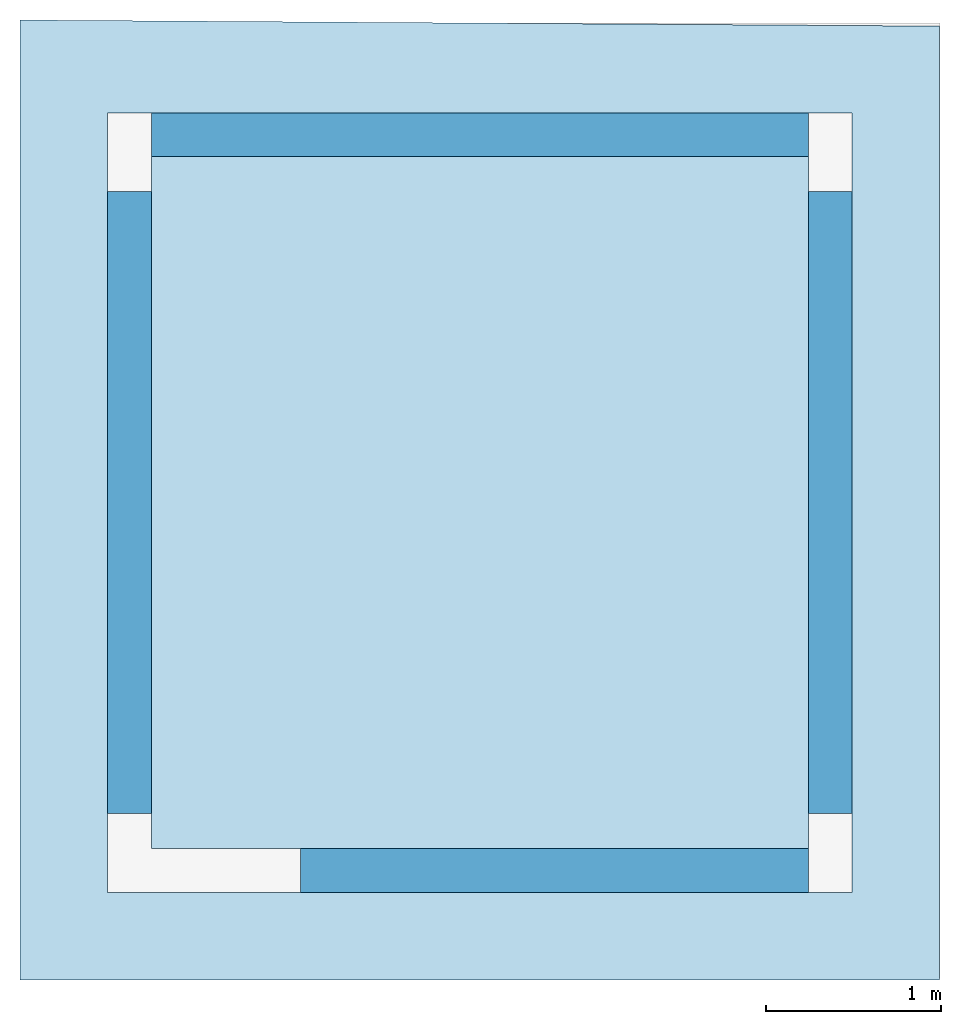
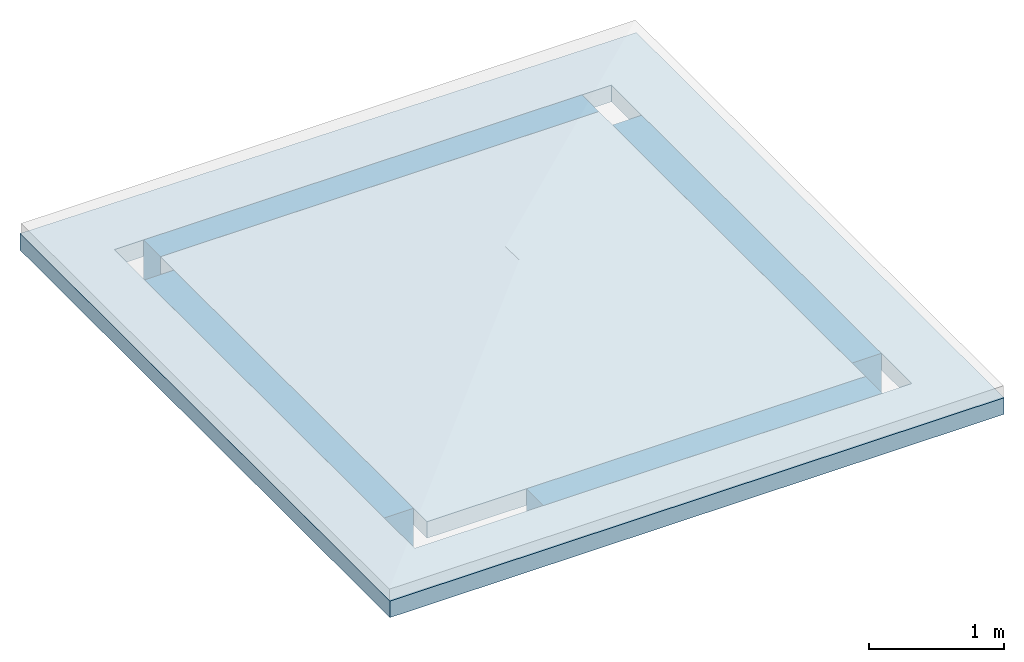
# One storey, part 1 of 2: 4 beams, 1 slab.
"""IFC4X3_ADD2 building model written with IfcOpenShell, lengths in metres."""

from ifc_helpers import new_model, entity, si_unit, converted_unit, frame, origin_with_axes, origin_2d_with_axis, place, context, subcontext, project, spatial, indexed_curve, rectangle, outline, composite_profile, extrude, material, layer, layer_set, layer_usage, material_profile, profile_set, profile_usage, type_object, element, save


model = new_model("IFC4X3_ADD2")

# Units and contexts
model_context = context("Model", 3, precision=1e-05, world=origin_with_axes())
plan_context = context("Plan", 2, precision=1e-05, world=origin_2d_with_axis())
body_context = subcontext(model_context, "Body", "Model", "MODEL_VIEW")
ifc_project = project(units=[si_unit("VOLUMEUNIT", "CUBIC_METRE"), si_unit("LENGTHUNIT", "METRE"), converted_unit("PLANEANGLEUNIT", "degree", entity("IfcReal", 0.0174532925199433), si_unit("PLANEANGLEUNIT", "RADIAN"), dimensions=[0, 0, 0, 0, 0, 0, 0]), si_unit("AREAUNIT", "SQUARE_METRE")], contexts=[model_context, plan_context])

# Site, building, storey
site_placement = place(None, origin_with_axes())
site = spatial("IfcSite", under=ifc_project, at=site_placement)
building_placement = place(site_placement, origin_with_axes())
building = spatial("IfcBuilding", under=site, at=building_placement, Name="Building")
storey_placement = place(building_placement, frame((0.0, 0.0, 3.40000009536743), z_axis=(0.0, 0.0, 1.0), x_axis=(1.0, 0.0, 0.0)))
storey = spatial("IfcBuildingStorey", under=building, at=storey_placement, Name="R1")

# Beams
ifc_material_1 = material()
ifc_material_profile = material_profile(ifc_material_1, rectangle(XDim=0.25, YDim=0.5))
ifc_profile_set = profile_set([ifc_material_profile])
ifc_profile_usage_1 = profile_usage(ifc_profile_set, cardinal=8)
beam_type = type_object("IfcBeamType", Name="BEM-250x500", PredefinedType="BEAM", material=ifc_profile_set)
beam_1_placement = place(storey_placement, frame((4.5, 0.724999904632568, 0.0), z_axis=(-1.5099578831723e-07, 0.999999999999986, 7.54979012640422e-08), x_axis=(-0.999999999999985, -1.50995802528084e-07, 8.74227907843292e-08)))
element("IfcBeam", 1, at=beam_1_placement, inside=storey, type_object=beam_type, material=ifc_profile_usage_1, Name="250x500", context=body_context, shape_type="SweptSolid", body=[
    extrude(rectangle(XDim=0.25, YDim=0.5), frame((0.0, -0.25, 0.0), z_axis=(0.0, 0.0, 1.0), x_axis=(1.0, 0.0, 0.0)), (0.0, 0.0, 1.0), 3.55000012894753),
])
ifc_profile_usage_2 = profile_usage(ifc_profile_set, cardinal=8)
beam_2_placement = place(storey_placement, frame((4.375, 0.400000095367432, 0.0), z_axis=(-0.999999999999996, 4.37113989448788e-08, 7.5497901264043e-08), x_axis=(-4.37113882867376e-08, -0.999999999999992, 1.1920928955078e-07)))
element("IfcBeam", 2, at=beam_2_placement, inside=storey, type_object=beam_type, material=ifc_profile_usage_2, Name="250x500", context=body_context, shape_type="SweptSolid", body=[
    extrude(rectangle(XDim=0.25, YDim=0.5), frame((0.0, -0.25, 0.0), z_axis=(0.0, 0.0, 1.0), x_axis=(1.0, 0.0, 0.0)), (0.0, 0.0, 1.0), 2.90000009536743),
])
ifc_profile_usage_3 = profile_usage(ifc_profile_set, cardinal=8)
beam_3_placement = place(storey_placement, frame((0.500000178813934, 0.724999904632568, 0.0), z_axis=(-1.5099578831723e-07, 0.999999999999986, 7.54979012640422e-08), x_axis=(-0.999999999999985, -1.50995802528084e-07, 8.74227907843292e-08)))
element("IfcBeam", 3, at=beam_3_placement, inside=storey, type_object=beam_type, material=ifc_profile_usage_3, Name="250x500", context=body_context, shape_type="SweptSolid", body=[
    extrude(rectangle(XDim=0.25, YDim=0.5), frame((0.0, -0.25, 0.0), z_axis=(0.0, 0.0, 1.0), x_axis=(1.0, 0.0, 0.0)), (0.0, 0.0, 1.0), 3.55000012894753),
])
ifc_profile_usage_4 = profile_usage(ifc_profile_set, cardinal=8)
beam_4_placement = place(storey_placement, frame((4.375, 4.59999990463257, 0.0), z_axis=(-0.999999999999996, 4.37113989448788e-08, 7.5497901264043e-08), x_axis=(-4.37113882867376e-08, -0.999999999999992, 1.1920928955078e-07)))
element("IfcBeam", 4, at=beam_4_placement, inside=storey, type_object=beam_type, material=ifc_profile_usage_4, Name="250x500", context=body_context, shape_type="SweptSolid", body=[
    extrude(rectangle(XDim=0.25, YDim=0.5), frame((0.0, -0.25, 0.0), z_axis=(0.0, 0.0, 1.0), x_axis=(1.0, 0.0, 0.0)), (0.0, 0.0, 1.0), 3.75000025431315),
])

# Slab
ifc_material_2 = material(Name="C25/30", Category="concrete")
ifc_layer = layer(ifc_material_2, 0.150000005960464)
ifc_layer_set = layer_set([ifc_layer])
ifc_layer_usage = layer_usage(ifc_layer_set, "AXIS3", "POSITIVE", -0.150000005960464)
slab_type = type_object("IfcSlabType", Name="SLB-150", PredefinedType="ROOF", material=ifc_layer_set)
slab_placement = place(storey_placement, frame((0.625, 4.5, 0.0), z_axis=(0.0, 0.0, 1.0), x_axis=(1.0, 0.0, 0.0)))
element("IfcSlab", 5, at=slab_placement, inside=storey, type_object=slab_type, material=ifc_layer_usage, Name="150", context=body_context, shape_type="SweptSolid", body=[
    extrude(composite_profile([outline(indexed_curve([(-0.74999988079071, 0.75501674413681), (4.5, 0.720016479492188), (4.5, -4.72499990463257), (-0.750000357627869, -4.72499942779541), (-0.74999988079071, 0.75501674413681)]), holes=[indexed_curve([(-0.249999955296516, 0.224999874830246), (4.0, 0.223338752985001), (4.0, -4.22499990463257), (-0.250000238418579, -4.22499942779541), (-0.249999955296516, 0.224999874830246)])]), outline(indexed_curve([(0.0, 0.0), (3.75, -0.0250000953674316), (3.75, -3.97499990463257), (-2.38418579101562e-07, -3.97499966621399), (0.0, 0.0)]))]), frame((0.0, 0.0, -0.150000005960464), z_axis=(0.0, 0.0, 1.0), x_axis=(1.0, 0.0, 0.0)), (0.0, 0.0, 1.0), 0.150000005960464),
])

save(model, "model.ifc")
